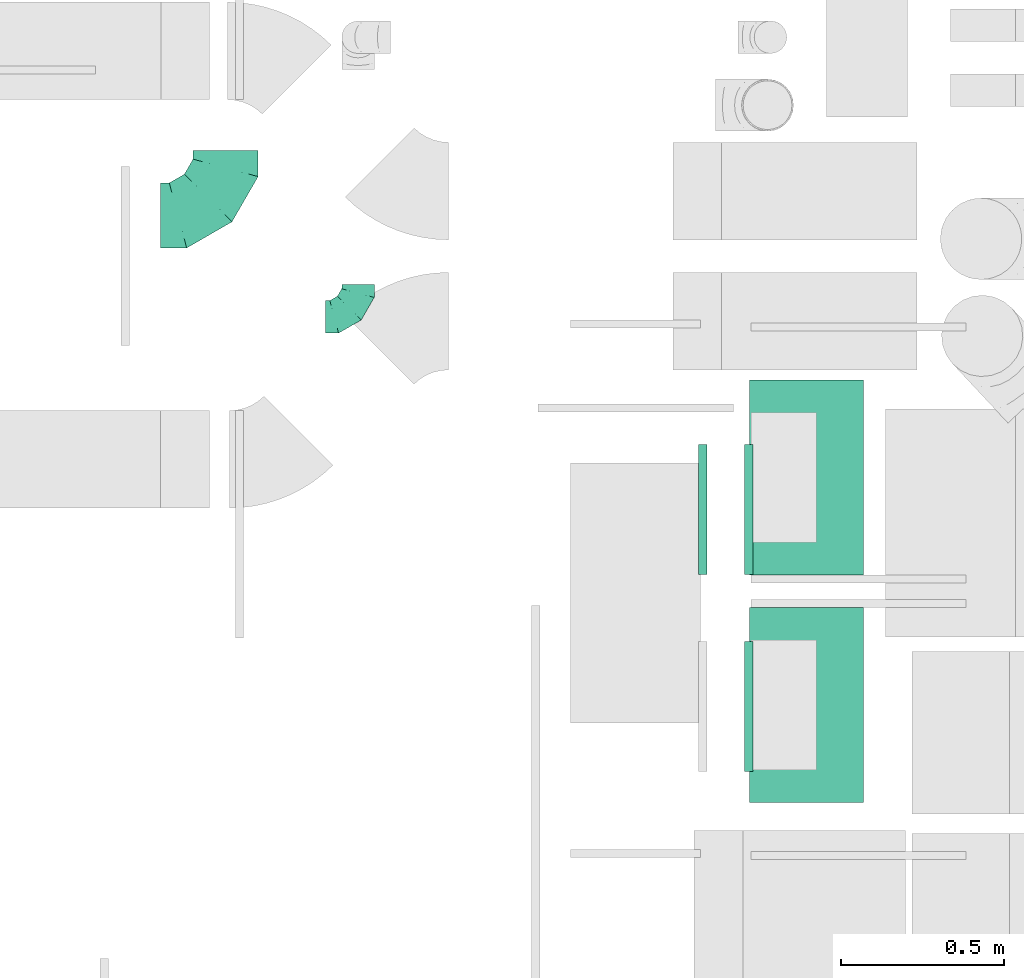
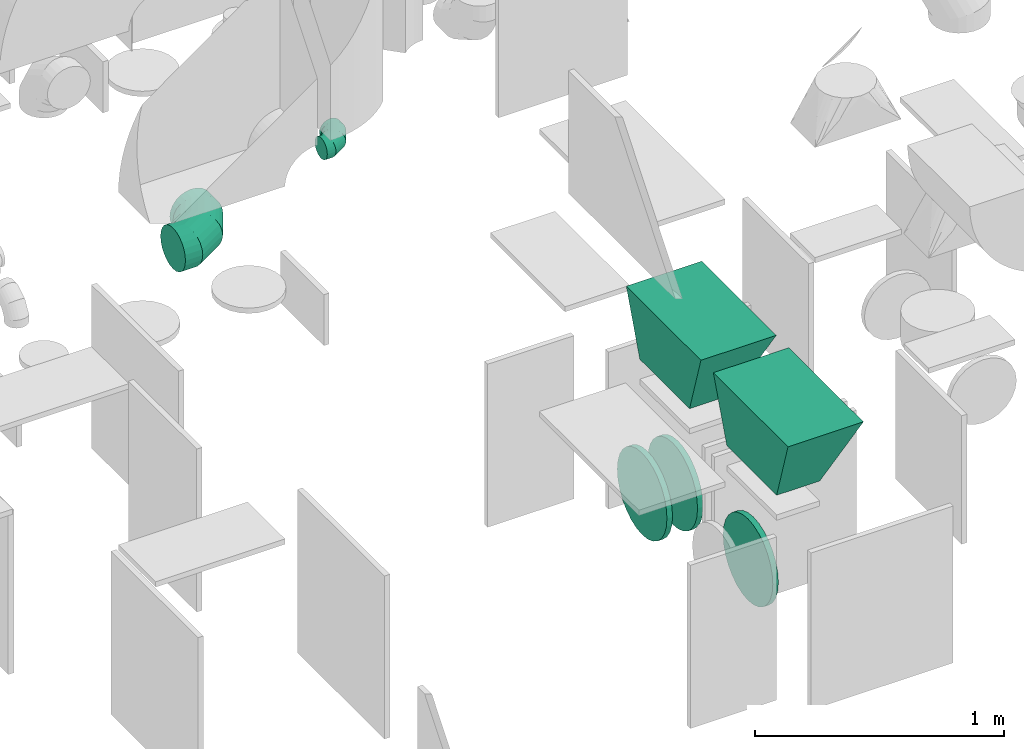
# One storey, part 16 of 59: 7 flow fittings.
"""IFC2X3 building model written with IfcOpenShell, lengths in millimetres."""

from ifc_helpers import new_model, entity, si_unit, converted_unit, derived_unit, direction, frame, origin, place, context, subcontext, project, spatial, faceted_brep, source, transform, mapped, material, type_object, type_shapes, element, save


model = new_model("IFC2X3")

# Units and contexts
model_context = context("Model", 3, precision=0.01, world=origin(), true_north=direction((6.12303176911189e-17, 1.0)))
body_context = subcontext(model_context, "Body", "Model", "MODEL_VIEW")
ifc_project = project(units=[si_unit("LENGTHUNIT", "METRE", prefix="MILLI"), si_unit("AREAUNIT", "SQUARE_METRE"), si_unit("VOLUMEUNIT", "CUBIC_METRE"), converted_unit("PLANEANGLEUNIT", "DEGREE", entity("IfcRatioMeasure", 0.0174532925199433), si_unit("PLANEANGLEUNIT", "RADIAN"), dimensions=[0, 0, 0, 0, 0, 0, 0]), si_unit("MASSUNIT", "GRAM", prefix="KILO"), derived_unit("MASSDENSITYUNIT", [(si_unit("MASSUNIT", "GRAM", prefix="KILO"), 1), (si_unit("LENGTHUNIT", "METRE"), -3)]), derived_unit("MOMENTOFINERTIAUNIT", [(si_unit("LENGTHUNIT", "METRE"), 4)]), si_unit("TIMEUNIT", "SECOND"), si_unit("FREQUENCYUNIT", "HERTZ"), si_unit("THERMODYNAMICTEMPERATUREUNIT", "DEGREE_CELSIUS"), derived_unit("THERMALTRANSMITTANCEUNIT", [(si_unit("MASSUNIT", "GRAM", prefix="KILO"), 1), (si_unit("THERMODYNAMICTEMPERATUREUNIT", "KELVIN"), -1), (si_unit("TIMEUNIT", "SECOND"), -3)]), derived_unit("VOLUMETRICFLOWRATEUNIT", [(si_unit("LENGTHUNIT", "METRE"), 3), (si_unit("TIMEUNIT", "SECOND"), -1)]), derived_unit("MASSFLOWRATEUNIT", [(si_unit("MASSUNIT", "GRAM", prefix="KILO"), 1), (si_unit("TIMEUNIT", "SECOND"), -1)]), derived_unit("ROTATIONALFREQUENCYUNIT", [(si_unit("TIMEUNIT", "SECOND"), -1)]), si_unit("ELECTRICCURRENTUNIT", "AMPERE"), si_unit("ELECTRICVOLTAGEUNIT", "VOLT"), si_unit("POWERUNIT", "WATT"), si_unit("FORCEUNIT", "NEWTON", prefix="KILO"), si_unit("ILLUMINANCEUNIT", "LUX"), si_unit("LUMINOUSFLUXUNIT", "LUMEN"), si_unit("LUMINOUSINTENSITYUNIT", "CANDELA"), derived_unit("USERDEFINED", [(si_unit("MASSUNIT", "GRAM", prefix="KILO"), -1), (si_unit("LENGTHUNIT", "METRE"), -2), (si_unit("TIMEUNIT", "SECOND"), 3), (si_unit("LUMINOUSFLUXUNIT", "LUMEN"), 1)]), derived_unit("LINEARVELOCITYUNIT", [(si_unit("LENGTHUNIT", "METRE"), 1), (si_unit("TIMEUNIT", "SECOND"), -1)]), si_unit("PRESSUREUNIT", "PASCAL"), derived_unit("USERDEFINED", [(si_unit("LENGTHUNIT", "METRE"), -2), (si_unit("MASSUNIT", "GRAM", prefix="KILO"), 1), (si_unit("TIMEUNIT", "SECOND"), -2)]), derived_unit("LINEARFORCEUNIT", [(si_unit("MASSUNIT", "GRAM", prefix="KILO"), 1), (si_unit("LENGTHUNIT", "METRE"), 1), (si_unit("TIMEUNIT", "SECOND"), -2), (si_unit("LENGTHUNIT", "METRE"), -1)]), derived_unit("PLANARFORCEUNIT", [(si_unit("MASSUNIT", "GRAM", prefix="KILO"), 1), (si_unit("LENGTHUNIT", "METRE"), 1), (si_unit("TIMEUNIT", "SECOND"), -2), (si_unit("LENGTHUNIT", "METRE"), -2)])], contexts=[model_context])

# Site, building, storey
site_placement = place(None, origin())
site = spatial("IfcSite", under=ifc_project, at=site_placement, CompositionType="ELEMENT")
building_placement = place(site_placement, origin())
building = spatial("IfcBuilding", under=site, at=building_placement, CompositionType="ELEMENT")
storey_placement = place(building_placement, frame((0.0, 0.0, 28200.0)))
storey = spatial("IfcBuildingStorey", under=building, at=storey_placement, CompositionType="ELEMENT", Elevation=28200.0)

# Flow fittings
ifc_material = material()
duct_fitting_type_1 = type_object("IfcDuctFittingType", PredefinedType="NOTDEFINED", material=ifc_material)
shared_shape_1 = source(origin(), body_context, "Body", "Brep", [
    faceted_brep([(-100.0, 0.0, -50.0), (-100.0, -12.94, -48.3), (-100.0, -25.0, -43.3), (-100.0, -35.36, -35.36), (-100.0, -43.3, -25.0), (-100.0, -48.3, -12.94), (-100.0, -50.0, 0.0), (-100.0, -48.3, 12.94), (-100.0, -43.3, 25.0), (-100.0, -35.36, 35.36), (-100.0, -25.0, 43.3), (-100.0, -12.94, 48.3), (-100.0, 0.0, 50.0), (-100.0, 12.94, 48.3), (-100.0, 25.0, 43.3), (-100.0, 35.36, 35.36), (-100.0, 43.3, 25.0), (-100.0, 48.3, 12.94), (-100.0, 50.0, 0.0), (-100.0, 48.3, -12.94), (-100.0, 43.3, -25.0), (-100.0, 35.36, -35.36), (-100.0, 25.0, -43.3), (-100.0, 12.94, -48.3), (-76.67, 12.94, 48.3), (-79.9, 25.0, 43.3), (-73.21, 0.0, 50.0), (-82.68, 35.36, 35.36), (-86.15, 48.3, 12.94), (-86.6, 50.0, 0.0), (-84.81, 43.3, 25.0), (-84.81, 43.3, -25.0), (-82.68, 35.36, -35.36), (-86.15, 48.3, -12.94), (-76.67, 12.94, -48.3), (-73.21, 0.0, -50.0), (-79.9, 25.0, -43.3), (-69.74, -12.94, -48.3), (-66.51, -25.0, -43.3), (-63.73, -35.36, -35.36), (-61.6, -43.3, -25.0), (-60.26, -48.3, -12.94), (-59.81, -50.0, 0.0), (-60.26, -48.3, 12.94), (-61.6, -43.3, 25.0), (-63.73, -35.36, 35.36), (-66.51, -25.0, 43.3), (-69.74, -12.94, 48.3), (-36.27, 36.27, 48.3), (-45.1, 45.1, 43.3), (-26.79, 26.79, 50.0), (-52.68, 52.68, 35.36), (-58.49, 58.49, 25.0), (-62.15, 62.15, 12.94), (-63.4, 63.4, 0.0), (-62.15, 62.15, -12.94), (-58.49, 58.49, -25.0), (-52.68, 52.68, -35.36), (-36.27, 36.27, -48.3), (-26.79, 26.79, -50.0), (-45.1, 45.1, -43.3), (-17.32, 17.32, -48.3), (-8.49, 8.49, -43.3), (-0.91, 0.91, -35.36), (4.9, -4.9, -25.0), (8.56, -8.56, -12.94), (9.81, -9.81, 0.0), (8.56, -8.56, 12.94), (4.9, -4.9, 25.0), (-0.91, 0.91, 35.36), (-8.49, 8.49, 43.3), (-17.32, 17.32, 48.3), (-12.94, 76.67, 48.3), (-25.0, 79.9, 43.3), (0.0, 73.21, 50.0), (-35.36, 82.68, 35.36), (-43.3, 84.81, 25.0), (-48.3, 86.15, 12.94), (-50.0, 86.6, 0.0), (-48.3, 86.15, -12.94), (-43.3, 84.81, -25.0), (-35.36, 82.68, -35.36), (-12.94, 76.67, -48.3), (0.0, 73.21, -50.0), (-25.0, 79.9, -43.3), (12.94, 69.74, -48.3), (25.0, 66.51, -43.3), (35.36, 63.73, -35.36), (43.3, 61.6, -25.0), (48.3, 60.26, -12.94), (50.0, 59.81, 0.0), (48.3, 60.26, 12.94), (43.3, 61.6, 25.0), (35.36, 63.73, 35.36), (25.0, 66.51, 43.3), (12.94, 69.74, 48.3), (-12.94, 100.0, -48.3), (-25.0, 100.0, -43.3), (-35.36, 100.0, -35.36), (-43.3, 100.0, -25.0), (-48.3, 100.0, -12.94), (-50.0, 100.0, 0.0), (-48.3, 100.0, 12.94), (-43.3, 100.0, 25.0), (-35.36, 100.0, 35.36), (-25.0, 100.0, 43.3), (-12.94, 100.0, 48.3), (0.0, 100.0, 50.0), (12.94, 100.0, 48.3), (25.0, 100.0, 43.3), (35.36, 100.0, 35.36), (43.3, 100.0, 25.0), (48.3, 100.0, 12.94), (50.0, 100.0, 0.0), (48.3, 100.0, -12.94), (43.3, 100.0, -25.0), (35.36, 100.0, -35.36), (25.0, 100.0, -43.3), (12.94, 100.0, -48.3), (0.0, 100.0, -50.0)], [[[0, 1, 2, 3, 4, 5, 6, 7, 8, 9, 10, 11, 12, 13, 14, 15, 16, 17, 18, 19, 20, 21, 22, 23]], [[24, 25, 14, 13]], [[26, 24, 13, 12]], [[14, 25, 27, 15]], [[28, 29, 18, 17]], [[30, 28, 17, 16]], [[15, 27, 30, 16]], [[20, 31, 32, 21]], [[33, 31, 20, 19]], [[18, 29, 33, 19]], [[34, 35, 0, 23]], [[36, 34, 23, 22]], [[32, 36, 22, 21]], [[2, 1, 37, 38]], [[3, 2, 38, 39]], [[0, 35, 37, 1]], [[5, 4, 40, 41]], [[6, 5, 41, 42]], [[3, 39, 40, 4]], [[6, 42, 43, 7]], [[7, 43, 44, 8]], [[8, 44, 45, 9]], [[10, 46, 47, 11]], [[11, 47, 26, 12]], [[10, 9, 45, 46]], [[48, 49, 25, 24]], [[50, 48, 24, 26]], [[27, 25, 49, 51]], [[52, 53, 28, 30]], [[51, 52, 30, 27]], [[29, 28, 53, 54]], [[55, 56, 31, 33]], [[54, 55, 33, 29]], [[57, 32, 31, 56]], [[58, 59, 35, 34]], [[60, 58, 34, 36]], [[57, 60, 36, 32]], [[37, 35, 59, 61]], [[38, 37, 61, 62]], [[39, 38, 62, 63]], [[41, 40, 64, 65]], [[42, 41, 65, 66]], [[63, 64, 40, 39]], [[43, 42, 66, 67]], [[44, 43, 67, 68]], [[68, 69, 45, 44]], [[46, 45, 69, 70]], [[47, 46, 70, 71]], [[26, 47, 71, 50]], [[72, 73, 49, 48]], [[74, 72, 48, 50]], [[51, 49, 73, 75]], [[76, 77, 53, 52]], [[75, 76, 52, 51]], [[54, 53, 77, 78]], [[79, 80, 56, 55]], [[78, 79, 55, 54]], [[81, 57, 56, 80]], [[82, 83, 59, 58]], [[84, 82, 58, 60]], [[81, 84, 60, 57]], [[61, 59, 83, 85]], [[62, 61, 85, 86]], [[63, 62, 86, 87]], [[65, 64, 88, 89]], [[66, 65, 89, 90]], [[87, 88, 64, 63]], [[67, 66, 90, 91]], [[68, 67, 91, 92]], [[92, 93, 69, 68]], [[70, 69, 93, 94]], [[71, 70, 94, 95]], [[50, 71, 95, 74]], [[96, 97, 98, 99, 100, 101, 102, 103, 104, 105, 106, 107, 108, 109, 110, 111, 112, 113, 114, 115, 116, 117, 118, 119]], [[72, 74, 107, 106]], [[73, 72, 106, 105]], [[75, 73, 105, 104]], [[77, 76, 103, 102]], [[78, 77, 102, 101]], [[75, 104, 103, 76]], [[78, 101, 100, 79]], [[79, 100, 99, 80]], [[80, 99, 98, 81]], [[96, 119, 83, 82]], [[97, 96, 82, 84]], [[84, 81, 98, 97]], [[83, 119, 118, 85]], [[85, 118, 117, 86]], [[86, 117, 116, 87]], [[88, 115, 114, 89]], [[89, 114, 113, 90]], [[87, 116, 115, 88]], [[91, 90, 113, 112]], [[92, 91, 112, 111]], [[93, 92, 111, 110]], [[95, 94, 109, 108]], [[74, 95, 108, 107]], [[110, 109, 94, 93]]]),
])
type_shapes(duct_fitting_type_1, [shared_shape_1])
flow_fitting_1_placement = place(storey_placement, frame((47101.64, 11302.74, 2403.42)))
element("IfcFlowFitting", 1, at=flow_fitting_1_placement, inside=storey, type_object=duct_fitting_type_1, material=ifc_material, context=body_context, shape_type="MappedRepresentation", body=[
    mapped(shared_shape_1, transform((0.0, 0.0, 0.0), scale=1.0)),
])
duct_fitting_type_2 = type_object("IfcDuctFittingType", PredefinedType="NOTDEFINED", material=ifc_material)
shared_shape_2 = source(origin(), body_context, "Body", "Brep", [
    faceted_brep([(-200.0, 0.0, -100.0), (-200.0, -25.88, -96.59), (-200.0, -50.0, -86.6), (-200.0, -70.71, -70.71), (-200.0, -86.6, -50.0), (-200.0, -96.59, -25.88), (-200.0, -100.0, 0.0), (-200.0, -96.59, 25.88), (-200.0, -86.6, 50.0), (-200.0, -70.71, 70.71), (-200.0, -50.0, 86.6), (-200.0, -25.88, 96.59), (-200.0, 0.0, 100.0), (-200.0, 25.88, 96.59), (-200.0, 50.0, 86.6), (-200.0, 70.71, 70.71), (-200.0, 86.6, 50.0), (-200.0, 96.59, 25.88), (-200.0, 100.0, 0.0), (-200.0, 96.59, -25.88), (-200.0, 86.6, -50.0), (-200.0, 70.71, -70.71), (-200.0, 50.0, -86.6), (-200.0, 25.88, -96.59), (-153.35, 25.88, 96.59), (-159.81, 50.0, 86.6), (-146.41, 0.0, 100.0), (-165.36, 70.71, 70.71), (-172.29, 96.59, 25.88), (-173.21, 100.0, 0.0), (-169.62, 86.6, 50.0), (-169.62, 86.6, -50.0), (-165.36, 70.71, -70.71), (-172.29, 96.59, -25.88), (-153.35, 25.88, -96.59), (-146.41, 0.0, -100.0), (-159.81, 50.0, -86.6), (-139.48, -25.88, -96.59), (-133.01, -50.0, -86.6), (-127.46, -70.71, -70.71), (-123.21, -86.6, -50.0), (-120.53, -96.59, -25.88), (-119.62, -100.0, 0.0), (-120.53, -96.59, 25.88), (-123.21, -86.6, 50.0), (-127.46, -70.71, 70.71), (-133.01, -50.0, 86.6), (-139.48, -25.88, 96.59), (-72.54, 72.54, 96.59), (-90.19, 90.19, 86.6), (-53.59, 53.59, 100.0), (-105.35, 105.35, 70.71), (-116.99, 116.99, 50.0), (-124.3, 124.3, 25.88), (-126.79, 126.79, 0.0), (-124.3, 124.3, -25.88), (-116.99, 116.99, -50.0), (-105.35, 105.35, -70.71), (-72.54, 72.54, -96.59), (-53.59, 53.59, -100.0), (-90.19, 90.19, -86.6), (-34.64, 34.64, -96.59), (-16.99, 16.99, -86.6), (-1.83, 1.83, -70.71), (9.81, -9.81, -50.0), (17.12, -17.12, -25.88), (19.62, -19.62, 0.0), (17.12, -17.12, 25.88), (9.81, -9.81, 50.0), (-1.83, 1.83, 70.71), (-16.99, 16.99, 86.6), (-34.64, 34.64, 96.59), (-25.88, 153.35, 96.59), (-50.0, 159.81, 86.6), (0.0, 146.41, 100.0), (-70.71, 165.36, 70.71), (-86.6, 169.62, 50.0), (-96.59, 172.29, 25.88), (-100.0, 173.21, 0.0), (-96.59, 172.29, -25.88), (-86.6, 169.62, -50.0), (-70.71, 165.36, -70.71), (-25.88, 153.35, -96.59), (0.0, 146.41, -100.0), (-50.0, 159.81, -86.6), (25.88, 139.48, -96.59), (50.0, 133.01, -86.6), (70.71, 127.46, -70.71), (86.6, 123.21, -50.0), (96.59, 120.53, -25.88), (100.0, 119.62, 0.0), (96.59, 120.53, 25.88), (86.6, 123.21, 50.0), (70.71, 127.46, 70.71), (50.0, 133.01, 86.6), (25.88, 139.48, 96.59), (-25.88, 200.0, -96.59), (-50.0, 200.0, -86.6), (-70.71, 200.0, -70.71), (-86.6, 200.0, -50.0), (-96.59, 200.0, -25.88), (-100.0, 200.0, 0.0), (-96.59, 200.0, 25.88), (-86.6, 200.0, 50.0), (-70.71, 200.0, 70.71), (-50.0, 200.0, 86.6), (-25.88, 200.0, 96.59), (0.0, 200.0, 100.0), (25.88, 200.0, 96.59), (50.0, 200.0, 86.6), (70.71, 200.0, 70.71), (86.6, 200.0, 50.0), (96.59, 200.0, 25.88), (100.0, 200.0, 0.0), (96.59, 200.0, -25.88), (86.6, 200.0, -50.0), (70.71, 200.0, -70.71), (50.0, 200.0, -86.6), (25.88, 200.0, -96.59), (0.0, 200.0, -100.0)], [[[0, 1, 2, 3, 4, 5, 6, 7, 8, 9, 10, 11, 12, 13, 14, 15, 16, 17, 18, 19, 20, 21, 22, 23]], [[24, 25, 14, 13]], [[26, 24, 13, 12]], [[14, 25, 27, 15]], [[28, 29, 18, 17]], [[30, 28, 17, 16]], [[15, 27, 30, 16]], [[20, 31, 32, 21]], [[33, 31, 20, 19]], [[18, 29, 33, 19]], [[34, 35, 0, 23]], [[36, 34, 23, 22]], [[32, 36, 22, 21]], [[1, 0, 35, 37]], [[2, 1, 37, 38]], [[38, 39, 3, 2]], [[5, 4, 40, 41]], [[6, 5, 41, 42]], [[39, 40, 4, 3]], [[6, 42, 43, 7]], [[7, 43, 44, 8]], [[8, 44, 45, 9]], [[9, 45, 46, 10]], [[10, 46, 47, 11]], [[26, 12, 11, 47]], [[48, 49, 25, 24]], [[50, 48, 24, 26]], [[27, 25, 49, 51]], [[52, 53, 28, 30]], [[51, 52, 30, 27]], [[29, 28, 53, 54]], [[55, 56, 31, 33]], [[54, 55, 33, 29]], [[32, 31, 56, 57]], [[58, 59, 35, 34]], [[60, 58, 34, 36]], [[57, 60, 36, 32]], [[37, 35, 59, 61]], [[38, 37, 61, 62]], [[39, 38, 62, 63]], [[41, 40, 64, 65]], [[42, 41, 65, 66]], [[63, 64, 40, 39]], [[43, 42, 66, 67]], [[44, 43, 67, 68]], [[68, 69, 45, 44]], [[46, 45, 69, 70]], [[47, 46, 70, 71]], [[26, 47, 71, 50]], [[72, 73, 49, 48]], [[74, 72, 48, 50]], [[51, 49, 73, 75]], [[76, 77, 53, 52]], [[75, 76, 52, 51]], [[54, 53, 77, 78]], [[79, 80, 56, 55]], [[78, 79, 55, 54]], [[57, 56, 80, 81]], [[82, 83, 59, 58]], [[84, 82, 58, 60]], [[81, 84, 60, 57]], [[61, 59, 83, 85]], [[62, 61, 85, 86]], [[63, 62, 86, 87]], [[65, 64, 88, 89]], [[66, 65, 89, 90]], [[87, 88, 64, 63]], [[67, 66, 90, 91]], [[68, 67, 91, 92]], [[92, 93, 69, 68]], [[70, 69, 93, 94]], [[71, 70, 94, 95]], [[50, 71, 95, 74]], [[96, 97, 98, 99, 100, 101, 102, 103, 104, 105, 106, 107, 108, 109, 110, 111, 112, 113, 114, 115, 116, 117, 118, 119]], [[72, 74, 107, 106]], [[73, 72, 106, 105]], [[75, 73, 105, 104]], [[102, 101, 78, 77]], [[103, 102, 77, 76]], [[75, 104, 103, 76]], [[78, 101, 100, 79]], [[79, 100, 99, 80]], [[80, 99, 98, 81]], [[84, 97, 96, 82]], [[82, 96, 119, 83]], [[84, 81, 98, 97]], [[118, 117, 86, 85]], [[119, 118, 85, 83]], [[116, 87, 86, 117]], [[88, 115, 114, 89]], [[89, 114, 113, 90]], [[115, 88, 87, 116]], [[91, 90, 113, 112]], [[92, 91, 112, 111]], [[111, 110, 93, 92]], [[95, 94, 109, 108]], [[74, 95, 108, 107]], [[110, 109, 94, 93]]]),
])
type_shapes(duct_fitting_type_2, [shared_shape_2])
flow_fitting_2_placement = place(storey_placement, frame((46694.47, 11614.6, 1900.0)))
element("IfcFlowFitting", 2, at=flow_fitting_2_placement, inside=storey, type_object=duct_fitting_type_2, material=ifc_material, context=body_context, shape_type="MappedRepresentation", body=[
    mapped(shared_shape_2, transform((0.0, 0.0, 0.0), scale=1.0)),
])
duct_fitting_type_3 = type_object("IfcDuctFittingType", PredefinedType="NOTDEFINED", material=ifc_material)
shared_shape_3 = source(origin(), body_context, "Body", "Brep", [
    faceted_brep([(20.0, 200.0, 0.0), (20.0, 194.99, 44.5), (20.0, 180.19, 86.78), (20.0, 156.37, 124.7), (20.0, 124.7, 156.37), (20.0, 86.78, 180.19), (20.0, 44.5, 194.99), (20.0, 0.0, 200.0), (20.0, -44.5, 194.99), (20.0, -86.78, 180.19), (20.0, -124.7, 156.37), (20.0, -156.37, 124.7), (20.0, -180.19, 86.78), (20.0, -194.99, 44.5), (20.0, -200.0, 0.0), (20.0, -194.99, -44.5), (20.0, -180.19, -86.78), (20.0, -156.37, -124.7), (20.0, -124.7, -156.37), (20.0, -86.78, -180.19), (20.0, -44.5, -194.99), (20.0, 0.0, -200.0), (20.0, 44.5, -194.99), (20.0, 86.78, -180.19), (20.0, 124.7, -156.37), (20.0, 156.37, -124.7), (20.0, 180.19, -86.78), (20.0, 194.99, -44.5), (0.0, 0.0, 200.0), (0.0, 30.6, 196.55), (-6.1, 22.25, 197.49), (-6.1, 0.0, 200.0), (0.0, 44.5, 194.99), (-6.1, 44.5, 194.99), (0.0, 65.64, 187.59), (0.0, 86.78, 180.19), (-6.1, 65.64, 187.59), (-6.1, 86.78, 180.19), (0.0, 105.74, 168.28), (0.0, 124.7, 156.37), (-6.1, 105.74, 168.28), (-6.1, 124.7, 156.37), (0.0, 140.53, 140.53), (0.0, 156.37, 124.7), (-6.1, 140.53, 140.53), (-6.1, 156.37, 124.7), (0.0, 168.28, 105.74), (0.0, 180.19, 86.78), (-6.1, 168.28, 105.74), (-6.1, 180.19, 86.78), (0.0, 187.59, 65.64), (0.0, 194.99, 44.5), (-6.1, 187.59, 65.64), (-6.1, 194.99, 44.5), (0.0, 197.49, 22.25), (0.0, 200.0, 0.0), (-6.1, 200.0, 0.0), (-6.1, 196.55, 30.6), (0.0, 196.55, -30.6), (-6.1, 197.49, -22.25), (0.0, 194.99, -44.5), (-6.1, 194.99, -44.5), (0.0, 187.59, -65.64), (0.0, 180.19, -86.78), (-6.1, 187.59, -65.64), (-6.1, 180.19, -86.78), (0.0, 168.28, -105.74), (0.0, 156.37, -124.7), (-6.1, 168.28, -105.74), (-6.1, 156.37, -124.7), (0.0, 140.53, -140.53), (0.0, 124.7, -156.37), (-6.1, 140.53, -140.53), (-6.1, 124.7, -156.37), (0.0, 105.74, -168.28), (0.0, 86.78, -180.19), (-6.1, 86.78, -180.19), (-6.1, 105.74, -168.28), (0.0, 44.5, -194.99), (0.0, 65.64, -187.59), (-6.1, 44.5, -194.99), (-6.1, 65.64, -187.59), (0.0, 0.0, -200.0), (0.0, 30.6, -196.55), (-6.1, 22.25, -197.49), (-6.1, 0.0, -200.0), (0.0, -30.6, -196.55), (-6.1, -22.25, -197.49), (0.0, -44.5, -194.99), (-6.1, -44.5, -194.99), (0.0, -65.64, -187.59), (0.0, -86.78, -180.19), (-6.1, -65.64, -187.59), (-6.1, -86.78, -180.19), (0.0, -105.74, -168.28), (0.0, -124.7, -156.37), (-6.1, -105.74, -168.28), (-6.1, -124.7, -156.37), (0.0, -140.53, -140.53), (0.0, -156.37, -124.7), (-6.1, -140.53, -140.53), (-6.1, -156.37, -124.7), (0.0, -168.28, -105.74), (0.0, -180.19, -86.78), (-6.1, -168.28, -105.74), (-6.1, -180.19, -86.78), (0.0, -194.99, -44.5), (0.0, -196.55, -30.6), (0.0, -200.0, 0.0), (-6.1, -197.49, -22.25), (-6.1, -200.0, 0.0), (-6.1, -194.99, -44.5), (0.0, -187.59, -65.64), (-6.1, -187.59, -65.64), (0.0, -196.55, 30.6), (-6.1, -197.49, 22.25), (0.0, -194.99, 44.5), (-6.1, -194.99, 44.5), (0.0, -187.59, 65.64), (0.0, -180.19, 86.78), (-6.1, -187.59, 65.64), (-6.1, -180.19, 86.78), (0.0, -168.28, 105.74), (0.0, -156.37, 124.7), (-6.1, -168.28, 105.74), (-6.1, -156.37, 124.7), (0.0, -140.53, 140.53), (0.0, -124.7, 156.37), (-6.1, -140.53, 140.53), (-6.1, -124.7, 156.37), (0.0, -105.74, 168.28), (0.0, -86.78, 180.19), (-6.1, -105.74, 168.28), (-6.1, -86.78, 180.19), (0.0, -65.64, 187.59), (0.0, -44.5, 194.99), (-6.1, -65.64, 187.59), (-6.1, -44.5, 194.99), (0.0, -22.25, 197.49), (-6.1, -30.6, 196.55)], [[[0, 1, 2, 3, 4, 5, 6, 7, 8, 9, 10, 11, 12, 13, 14, 15, 16, 17, 18, 19, 20, 21, 22, 23, 24, 25, 26, 27]], [[28, 7, 6]], [[6, 29, 28]], [[28, 29, 30]], [[31, 28, 30]], [[6, 32, 29]], [[32, 33, 29]], [[29, 33, 30]], [[6, 5, 32]], [[5, 34, 32]], [[5, 35, 34]], [[36, 34, 35]], [[35, 37, 36]], [[33, 34, 36]], [[34, 33, 32]], [[4, 35, 5]], [[4, 38, 35]], [[4, 39, 38]], [[38, 39, 40]], [[39, 41, 40]], [[37, 38, 40]], [[38, 37, 35]], [[4, 3, 39]], [[3, 42, 39]], [[3, 43, 42]], [[44, 42, 43]], [[43, 45, 44]], [[41, 42, 44]], [[39, 42, 41]], [[43, 3, 2]], [[2, 46, 43]], [[45, 43, 46]], [[2, 47, 46]], [[47, 48, 46]], [[47, 49, 48]], [[45, 46, 48]], [[2, 1, 47]], [[1, 50, 47]], [[1, 51, 50]], [[52, 50, 51]], [[51, 53, 52]], [[49, 50, 52]], [[50, 49, 47]], [[0, 51, 1]], [[0, 54, 51]], [[0, 55, 54]], [[55, 56, 54]], [[56, 57, 54]], [[57, 51, 54]], [[51, 57, 53]], [[55, 0, 27]], [[27, 58, 55]], [[55, 58, 59]], [[56, 55, 59]], [[27, 60, 58]], [[60, 61, 58]], [[58, 61, 59]], [[27, 26, 60]], [[26, 62, 60]], [[26, 63, 62]], [[64, 62, 63]], [[63, 65, 64]], [[61, 62, 64]], [[62, 61, 60]], [[25, 63, 26]], [[25, 66, 63]], [[25, 67, 66]], [[66, 67, 68]], [[67, 69, 68]], [[65, 66, 68]], [[66, 65, 63]], [[25, 24, 67]], [[24, 70, 67]], [[24, 71, 70]], [[72, 70, 71]], [[71, 73, 72]], [[69, 70, 72]], [[67, 70, 69]], [[24, 23, 71]], [[23, 74, 71]], [[23, 75, 74]], [[74, 75, 76]], [[76, 77, 74]], [[73, 74, 77]], [[73, 71, 74]], [[23, 22, 78]], [[23, 78, 79]], [[23, 79, 75]], [[79, 78, 80]], [[79, 80, 81]], [[81, 75, 79]], [[75, 81, 76]], [[82, 22, 21]], [[22, 82, 83]], [[82, 84, 83]], [[82, 85, 84]], [[80, 83, 84]], [[83, 80, 78]], [[22, 83, 78]], [[82, 21, 20]], [[20, 86, 82]], [[82, 86, 87]], [[85, 82, 87]], [[20, 88, 86]], [[88, 89, 86]], [[86, 89, 87]], [[20, 19, 88]], [[19, 90, 88]], [[19, 91, 90]], [[92, 90, 91]], [[91, 93, 92]], [[89, 90, 92]], [[90, 89, 88]], [[18, 91, 19]], [[18, 94, 91]], [[18, 95, 94]], [[94, 95, 96]], [[95, 97, 96]], [[93, 94, 96]], [[94, 93, 91]], [[18, 17, 95]], [[17, 98, 95]], [[17, 99, 98]], [[100, 98, 99]], [[99, 101, 100]], [[97, 98, 100]], [[95, 98, 97]], [[17, 16, 99]], [[16, 102, 99]], [[16, 103, 102]], [[103, 104, 102]], [[103, 105, 104]], [[101, 102, 104]], [[101, 99, 102]], [[15, 14, 106]], [[14, 107, 106]], [[14, 108, 107]], [[108, 109, 107]], [[108, 110, 109]], [[111, 107, 109]], [[107, 111, 106]], [[16, 15, 106]], [[16, 106, 112]], [[16, 112, 103]], [[112, 106, 111]], [[112, 111, 113]], [[103, 113, 105]], [[113, 103, 112]], [[108, 14, 13]], [[13, 114, 108]], [[108, 114, 115]], [[110, 108, 115]], [[13, 116, 114]], [[116, 117, 114]], [[114, 117, 115]], [[13, 12, 116]], [[12, 118, 116]], [[12, 119, 118]], [[120, 118, 119]], [[119, 121, 120]], [[117, 118, 120]], [[118, 117, 116]], [[11, 119, 12]], [[11, 122, 119]], [[11, 123, 122]], [[122, 123, 124]], [[123, 125, 124]], [[121, 122, 124]], [[122, 121, 119]], [[11, 10, 123]], [[10, 126, 123]], [[10, 127, 126]], [[128, 126, 127]], [[127, 129, 128]], [[125, 126, 128]], [[123, 126, 125]], [[127, 10, 9]], [[9, 130, 127]], [[129, 127, 130]], [[9, 131, 130]], [[131, 132, 130]], [[131, 133, 132]], [[129, 130, 132]], [[9, 8, 131]], [[8, 134, 131]], [[8, 135, 134]], [[136, 134, 135]], [[135, 137, 136]], [[133, 134, 136]], [[134, 133, 131]], [[7, 135, 8]], [[7, 138, 135]], [[7, 28, 138]], [[28, 31, 138]], [[31, 139, 138]], [[139, 135, 138]], [[135, 139, 137]], [[87, 89, 92, 93, 96, 97, 100, 101, 104, 105, 113, 111, 109, 110, 115, 117, 120, 121, 124, 125, 128, 129, 132, 133, 136, 137, 139, 31, 30, 33, 36, 37, 40, 41, 44, 45, 48, 49, 52, 53, 57, 56, 59, 61, 64, 65, 68, 69, 72, 73, 77, 76, 81, 80, 84, 85]]]),
])
type_shapes(duct_fitting_type_3, [shared_shape_3])
flow_fitting_3_placement = place(storey_placement, frame((48310.88, 10105.16, 659.61), z_axis=(0.0, 0.0, -1.0), x_axis=(-1.0, 0.0, 0.0)))
element("IfcFlowFitting", 3, at=flow_fitting_3_placement, inside=storey, type_object=duct_fitting_type_3, material=ifc_material, context=body_context, shape_type="MappedRepresentation", body=[
    mapped(shared_shape_3, transform((0.0, 0.0, 0.0), scale=1.0)),
])
duct_fitting_type_4 = type_object("IfcDuctFittingType", PredefinedType="NOTDEFINED", material=ifc_material)
shared_shape_4 = source(origin(), body_context, "Body", "Brep", [
    faceted_brep([(20.0, 0.0, -200.0), (20.0, 44.5, -194.99), (20.0, 86.78, -180.19), (20.0, 124.7, -156.37), (20.0, 156.37, -124.7), (20.0, 180.19, -86.78), (20.0, 194.99, -44.5), (20.0, 200.0, 0.0), (20.0, 194.99, 44.5), (20.0, 180.19, 86.78), (20.0, 156.37, 124.7), (20.0, 124.7, 156.37), (20.0, 86.78, 180.19), (20.0, 44.5, 194.99), (20.0, 0.0, 200.0), (20.0, -44.5, 194.99), (20.0, -86.78, 180.19), (20.0, -124.7, 156.37), (20.0, -156.37, 124.7), (20.0, -180.19, 86.78), (20.0, -194.99, 44.5), (20.0, -200.0, 0.0), (20.0, -194.99, -44.5), (20.0, -180.19, -86.78), (20.0, -156.37, -124.7), (20.0, -124.7, -156.37), (20.0, -86.78, -180.19), (20.0, -44.5, -194.99), (0.0, 0.0, 200.0), (0.0, -30.6, 196.55), (0.0, -44.5, 194.99), (-6.1, -22.25, 197.49), (-6.1, 0.0, 200.0), (-6.1, -44.5, 194.99), (0.0, -65.64, 187.59), (-6.1, -65.64, 187.59), (0.0, -86.78, 180.19), (-6.1, -86.78, 180.19), (0.0, -105.74, 168.28), (-6.1, -105.74, 168.28), (0.0, -124.7, 156.37), (-6.1, -124.7, 156.37), (0.0, -140.53, 140.53), (-6.1, -140.53, 140.53), (0.0, -156.37, 124.7), (-6.1, -156.37, 124.7), (0.0, -168.28, 105.74), (0.0, -180.19, 86.78), (-6.1, -168.28, 105.74), (-6.1, -180.19, 86.78), (0.0, -187.59, 65.64), (-6.1, -187.59, 65.64), (0.0, -194.99, 44.5), (-6.1, -194.99, 44.5), (0.0, -197.49, 22.25), (-6.1, -196.55, 30.6), (-6.1, -200.0, 0.0), (0.0, -200.0, 0.0), (0.0, -196.55, -30.6), (0.0, -194.99, -44.5), (-6.1, -197.49, -22.25), (-6.1, -194.99, -44.5), (0.0, -187.59, -65.64), (-6.1, -187.59, -65.64), (0.0, -180.19, -86.78), (-6.1, -180.19, -86.78), (0.0, -168.28, -105.74), (-6.1, -168.28, -105.74), (0.0, -156.37, -124.7), (-6.1, -156.37, -124.7), (0.0, -140.53, -140.53), (-6.1, -140.53, -140.53), (0.0, -124.7, -156.37), (-6.1, -124.7, -156.37), (0.0, -105.74, -168.28), (-6.1, -105.74, -168.28), (-6.1, -86.78, -180.19), (0.0, -86.78, -180.19), (0.0, -44.5, -194.99), (0.0, -65.64, -187.59), (-6.1, -44.5, -194.99), (-6.1, -65.64, -187.59), (0.0, 0.0, -200.0), (0.0, -30.6, -196.55), (-6.1, -22.25, -197.49), (-6.1, 0.0, -200.0), (0.0, 30.6, -196.55), (0.0, 44.5, -194.99), (-6.1, 22.25, -197.49), (-6.1, 44.5, -194.99), (0.0, 65.64, -187.59), (-6.1, 65.64, -187.59), (0.0, 86.78, -180.19), (-6.1, 86.78, -180.19), (0.0, 105.74, -168.28), (-6.1, 105.74, -168.28), (0.0, 124.7, -156.37), (-6.1, 124.7, -156.37), (0.0, 140.53, -140.53), (-6.1, 140.53, -140.53), (0.0, 156.37, -124.7), (-6.1, 156.37, -124.7), (0.0, 168.28, -105.74), (-6.1, 168.28, -105.74), (0.0, 180.19, -86.78), (-6.1, 180.19, -86.78), (0.0, 194.99, -44.5), (0.0, 196.55, -30.6), (-6.1, 194.99, -44.5), (-6.1, 197.49, -22.25), (0.0, 200.0, 0.0), (-6.1, 200.0, 0.0), (0.0, 187.59, -65.64), (-6.1, 187.59, -65.64), (0.0, 196.55, 30.6), (0.0, 194.99, 44.5), (-6.1, 197.49, 22.25), (-6.1, 194.99, 44.5), (0.0, 187.59, 65.64), (-6.1, 187.59, 65.64), (0.0, 180.19, 86.78), (-6.1, 180.19, 86.78), (0.0, 168.28, 105.74), (-6.1, 168.28, 105.74), (0.0, 156.37, 124.7), (-6.1, 156.37, 124.7), (0.0, 140.53, 140.53), (-6.1, 140.53, 140.53), (0.0, 124.7, 156.37), (-6.1, 124.7, 156.37), (0.0, 105.74, 168.28), (0.0, 86.78, 180.19), (-6.1, 105.74, 168.28), (-6.1, 86.78, 180.19), (0.0, 65.64, 187.59), (-6.1, 65.64, 187.59), (0.0, 44.5, 194.99), (-6.1, 44.5, 194.99), (0.0, 22.25, 197.49), (-6.1, 30.6, 196.55)], [[[0, 1, 2, 3, 4, 5, 6, 7, 8, 9, 10, 11, 12, 13, 14, 15, 16, 17, 18, 19, 20, 21, 22, 23, 24, 25, 26, 27]], [[15, 14, 28]], [[15, 28, 29]], [[15, 29, 30]], [[31, 29, 28]], [[31, 28, 32]], [[31, 33, 29]], [[29, 33, 30]], [[30, 16, 15]], [[16, 30, 34]], [[30, 33, 34]], [[35, 34, 33]], [[36, 34, 35]], [[35, 37, 36]], [[16, 34, 36]], [[16, 36, 17]], [[17, 36, 38]], [[36, 37, 38]], [[39, 38, 37]], [[39, 40, 38]], [[39, 41, 40]], [[17, 38, 40]], [[40, 18, 17]], [[18, 40, 42]], [[41, 42, 40]], [[43, 42, 41]], [[44, 42, 43]], [[43, 45, 44]], [[18, 42, 44]], [[19, 18, 44]], [[19, 44, 46]], [[19, 46, 47]], [[46, 44, 45]], [[48, 46, 45]], [[46, 48, 47]], [[48, 49, 47]], [[47, 20, 19]], [[20, 47, 50]], [[47, 49, 50]], [[51, 50, 49]], [[52, 50, 51]], [[51, 53, 52]], [[20, 50, 52]], [[20, 52, 21]], [[21, 52, 54]], [[54, 52, 55]], [[53, 55, 52]], [[54, 55, 56]], [[54, 56, 57]], [[21, 54, 57]], [[22, 21, 57]], [[22, 57, 58]], [[22, 58, 59]], [[60, 58, 57]], [[60, 57, 56]], [[60, 61, 58]], [[58, 61, 59]], [[59, 23, 22]], [[23, 59, 62]], [[59, 61, 62]], [[63, 62, 61]], [[64, 62, 63]], [[63, 65, 64]], [[23, 62, 64]], [[23, 64, 24]], [[24, 64, 66]], [[64, 65, 66]], [[67, 66, 65]], [[67, 68, 66]], [[67, 69, 68]], [[24, 66, 68]], [[68, 25, 24]], [[25, 68, 70]], [[69, 70, 68]], [[71, 70, 69]], [[72, 70, 71]], [[71, 73, 72]], [[25, 70, 72]], [[72, 26, 25]], [[26, 72, 74]], [[74, 72, 73]], [[75, 74, 73]], [[74, 75, 76]], [[76, 77, 74]], [[26, 74, 77]], [[78, 27, 26]], [[26, 79, 78]], [[80, 78, 79]], [[26, 77, 79]], [[79, 77, 81]], [[76, 81, 77]], [[81, 80, 79]], [[0, 27, 82]], [[27, 83, 82]], [[27, 78, 83]], [[78, 80, 83]], [[84, 83, 80]], [[83, 84, 82]], [[84, 85, 82]], [[1, 0, 82]], [[1, 82, 86]], [[1, 86, 87]], [[88, 86, 82]], [[88, 82, 85]], [[88, 89, 86]], [[86, 89, 87]], [[87, 2, 1]], [[2, 87, 90]], [[87, 89, 90]], [[91, 90, 89]], [[92, 90, 91]], [[91, 93, 92]], [[2, 90, 92]], [[2, 92, 3]], [[3, 92, 94]], [[92, 93, 94]], [[95, 94, 93]], [[95, 96, 94]], [[95, 97, 96]], [[3, 94, 96]], [[96, 4, 3]], [[4, 96, 98]], [[97, 98, 96]], [[99, 98, 97]], [[100, 98, 99]], [[99, 101, 100]], [[4, 98, 100]], [[100, 5, 4]], [[5, 100, 102]], [[102, 100, 101]], [[103, 102, 101]], [[102, 103, 104]], [[103, 105, 104]], [[5, 102, 104]], [[106, 7, 6]], [[7, 106, 107]], [[106, 108, 107]], [[109, 107, 108]], [[107, 109, 110]], [[109, 111, 110]], [[7, 107, 110]], [[106, 6, 5]], [[5, 112, 106]], [[108, 106, 112]], [[5, 104, 112]], [[112, 104, 113]], [[105, 113, 104]], [[113, 108, 112]], [[8, 7, 110]], [[8, 110, 114]], [[8, 114, 115]], [[116, 114, 110]], [[116, 110, 111]], [[116, 117, 114]], [[114, 117, 115]], [[115, 9, 8]], [[9, 115, 118]], [[115, 117, 118]], [[119, 118, 117]], [[120, 118, 119]], [[119, 121, 120]], [[9, 118, 120]], [[9, 120, 10]], [[10, 120, 122]], [[120, 121, 122]], [[123, 122, 121]], [[123, 124, 122]], [[123, 125, 124]], [[10, 122, 124]], [[124, 11, 10]], [[11, 124, 126]], [[125, 126, 124]], [[127, 126, 125]], [[128, 126, 127]], [[127, 129, 128]], [[11, 126, 128]], [[12, 11, 128]], [[12, 128, 130]], [[12, 130, 131]], [[130, 128, 129]], [[132, 130, 129]], [[130, 132, 131]], [[132, 133, 131]], [[131, 13, 12]], [[13, 131, 134]], [[131, 133, 134]], [[135, 134, 133]], [[136, 134, 135]], [[135, 137, 136]], [[13, 134, 136]], [[13, 136, 14]], [[14, 136, 138]], [[138, 136, 139]], [[137, 139, 136]], [[138, 139, 32]], [[138, 32, 28]], [[14, 138, 28]], [[56, 55, 53, 51, 49, 48, 45, 43, 41, 39, 37, 35, 33, 31, 32, 139, 137, 135, 133, 132, 129, 127, 125, 123, 121, 119, 117, 116, 111, 109, 108, 113, 105, 103, 101, 99, 97, 95, 93, 91, 89, 88, 85, 84, 80, 81, 76, 75, 73, 71, 69, 67, 65, 63, 61, 60]]]),
])
type_shapes(duct_fitting_type_4, [shared_shape_4])
for number, where, z_axis, x_axis in (
    (4, (48310.88, 10710.16, 665.0), (0.0, 0.0, -1.0), (-1.0, 0.0, 0.0)),
    (5, (48155.03, 10710.16, 665.0), (0.0, 0.0, -1.0), (1.0, 0.0, 0.0)),
):
    element("IfcFlowFitting", number, at=place(storey_placement, frame(where, z_axis=z_axis, x_axis=x_axis)), inside=storey, type_object=duct_fitting_type_4, material=ifc_material, context=body_context, shape_type="MappedRepresentation", body=[
        mapped(shared_shape_4, transform((0.0, 0.0, 0.0), scale=1.0)),
    ])
duct_fitting_type_5 = type_object("IfcDuctFittingType", PredefinedType="NOTDEFINED", material=ifc_material)
shared_shape_5 = source(origin(), body_context, "Body", "Brep", [
    faceted_brep([(300.0, -300.0, 245.0), (300.0, -300.0, -105.0), (300.0, 300.0, -105.0), (300.0, 300.0, 245.0), (0.0, -200.0, 100.0), (0.0, 200.0, 100.0), (0.0, 200.0, -100.0), (0.0, -200.0, -100.0)], [[[0, 1, 2, 3]], [[4, 5, 6, 7]], [[4, 7, 1, 0]], [[7, 6, 2, 1]], [[6, 5, 3, 2]], [[5, 4, 0, 3]]]),
])
type_shapes(duct_fitting_type_5, [shared_shape_5])
for number, where, z_axis, x_axis in (
    (6, (48410.88, 10109.01, 1087.0), (1.0, 0.0, 0.0), (0.0, 0.0, 1.0)),
    (7, (48410.88, 10809.01, 1087.0), (1.0, 0.0, 0.0), (0.0, 0.0, 1.0)),
):
    element("IfcFlowFitting", number, at=place(storey_placement, frame(where, z_axis=z_axis, x_axis=x_axis)), inside=storey, type_object=duct_fitting_type_5, material=ifc_material, context=body_context, shape_type="MappedRepresentation", body=[
        mapped(shared_shape_5, transform((0.0, 0.0, 0.0), scale=1.0)),
    ])

save(model, "model.ifc")
